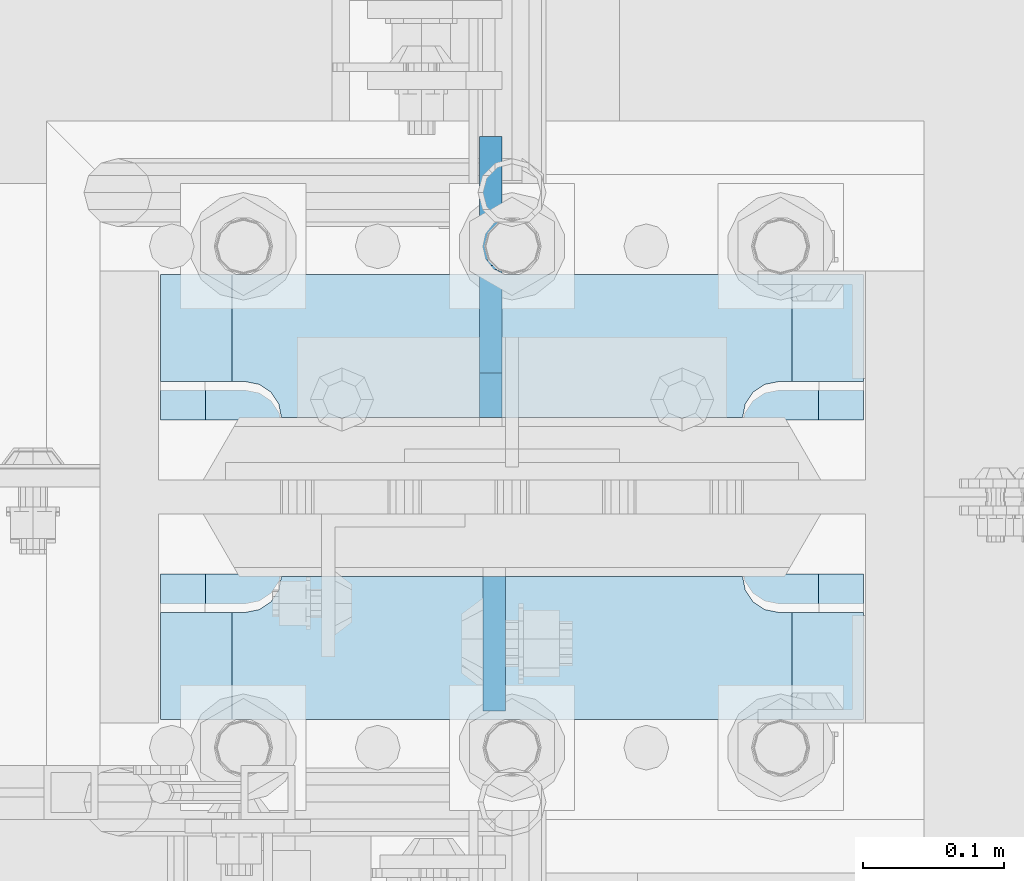
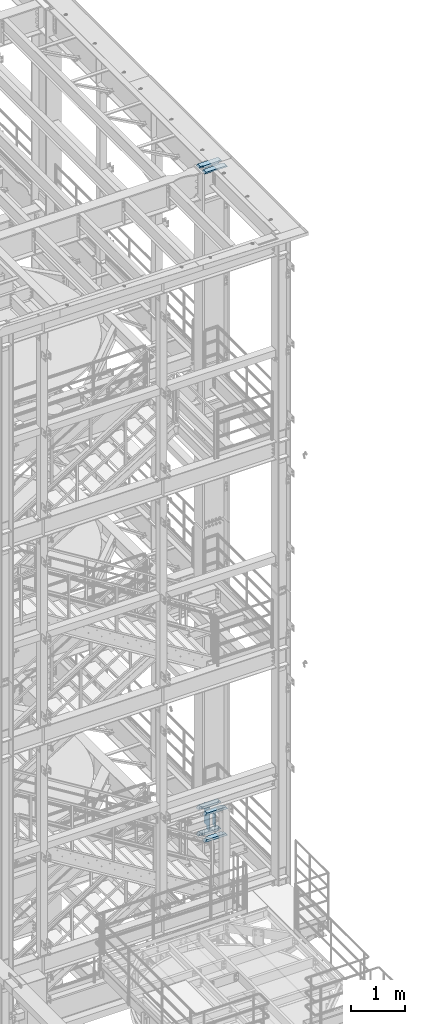
# One storey, part 1526 of 1876: 8 plates, 2 elements without a shape of their own.
"""IFC2X3 building model written with IfcOpenShell, lengths in millimetres."""

from ifc_helpers import new_model, si_unit, frame, origin_with_axes, place, context, subcontext, project, spatial, faceted_brep, material, type_object, element, aggregate, save


model = new_model("IFC2X3")

# Units and contexts
model_context = context("Model", 3, precision=1e-05, world=origin_with_axes())
body_context = subcontext(model_context, "Body", "Model", "MODEL_VIEW")
ifc_project = project(units=[si_unit("LENGTHUNIT", "METRE", prefix="MILLI"), si_unit("AREAUNIT", "SQUARE_METRE"), si_unit("VOLUMEUNIT", "CUBIC_METRE"), si_unit("MASSUNIT", "GRAM", prefix="KILO"), si_unit("TIMEUNIT", "SECOND"), si_unit("PLANEANGLEUNIT", "RADIAN"), si_unit("SOLIDANGLEUNIT", "STERADIAN"), si_unit("THERMODYNAMICTEMPERATUREUNIT", "DEGREE_CELSIUS"), si_unit("LUMINOUSINTENSITYUNIT", "LUMEN")], contexts=[model_context])

# Site, building, storey
site_placement = place(None, origin_with_axes())
site = spatial("IfcSite", under=ifc_project, at=site_placement, CompositionType="ELEMENT")
building_placement = place(site_placement, origin_with_axes())
building = spatial("IfcBuilding", under=site, at=building_placement, Name="Undefined", CompositionType="ELEMENT")
storey_placement = place(building_placement, origin_with_axes())
storey = spatial("IfcBuildingStorey", under=building, at=storey_placement, Name="Undefined", CompositionType="ELEMENT", Elevation=0.0)

# Assembly, plates
assembly_1_placement = place(storey_placement, origin_with_axes())
assembly_1 = element("IfcElementAssembly", 1, at=assembly_1_placement, inside=storey, Name="COLUMN", AssemblyPlace="NOTDEFINED", PredefinedType="RIGID_FRAME")
ifc_material_1 = material(Name="STEEL/A572-50")
plate_type_1 = type_object("IfcPlateType", PredefinedType="NOTDEFINED")
plate_1_placement = place(assembly_1_placement, frame((7869.2375, -4628.35625, 7531.10002441406), z_axis=(-1.0, 0.0, 0.0), x_axis=(0.0, -1.0, 0.0)))
plate_1 = element("IfcPlate", 2, at=plate_1_placement, type_object=plate_type_1, material=ifc_material_1, Name="PLATE", context=body_context, shape_type="Brep", body=[
    faceted_brep([(101.599998474121, -25.3999999999996, 498.475006103516), (101.599998474121, 25.3999999999996, 447.975004579813), (25.3999996185303, 25.3999999999996, 447.975004579813), (25.3999996185303, -25.3999999999996, 498.475006103516), (23.4665397733534, -25.3999999999996, 428.429848211837), (25.3999996185303, -25.3999999999996, 438.150007247925), (25.3999996185303, 25.3999999999996, 438.150007247925), (23.4665397733534, 25.3999999999996, 428.429848211837), (17.9605119723965, -25.3999999999996, 420.189495275529), (17.9605119723965, 25.3999999999996, 420.189495275529), (9.72015903608917, -25.3999999999996, 414.683467474573), (9.72015903608917, 25.3999999999996, 414.683467474573), (0.0, -25.3999999999996, 412.750007629395), (0.0, 25.3999999999996, 412.750007629395), (0.0, -25.3999999999996, 85.7249984741211), (0.0, 25.3999999999996, 85.7249984741211), (9.72015903609099, -25.3999999999996, 83.7915386289451), (9.72015903609099, 25.3999999999996, 83.7915386289451), (17.9605119723983, -25.3999999999996, 78.2855108279891), (17.9605119723983, 25.3999999999996, 78.2855108279891), (23.4665397733552, -25.3999999999996, 70.0451578916818), (23.4665397733552, 25.3999999999996, 70.0451578916818), (25.3999996185303, -25.3999999999996, 60.3249988555908), (25.3999996185303, 25.3999999999996, 60.3249988555908), (25.3999996185303, 25.3999999999996, 50.5000015237028), (25.3999996185303, -25.3999999999996, 0.0), (101.599998474121, 25.3999999999996, 50.5000015237028), (101.599998474121, -25.3999999999996, 0.0)], [[[0, 1, 2, 3]], [[4, 5, 6, 7]], [[8, 4, 7, 9]], [[10, 8, 9, 11]], [[12, 10, 11, 13]], [[14, 12, 13, 15]], [[16, 14, 15, 17]], [[18, 16, 17, 19]], [[20, 18, 19, 21]], [[22, 20, 21, 23]], [[22, 23, 24, 25]], [[26, 27, 25, 24]], [[5, 4, 8, 10, 12, 14, 16, 18, 20, 22, 25, 27, 0, 3]], [[6, 5, 3, 2]], [[26, 24, 23, 21, 19, 17, 15, 13, 11, 9, 7, 6, 2, 1]], [[27, 26, 1, 0]]]),
])
plate_2_placement = place(assembly_1_placement, frame((7869.2375, -4628.35625, 8128.0), z_axis=(-1.0, 0.0, 0.0), x_axis=(0.0, -1.0, 0.0)))
plate_2 = element("IfcPlate", 3, at=plate_2_placement, type_object=plate_type_1, material=ifc_material_1, Name="PLATE", context=body_context, shape_type="Brep", body=[
    faceted_brep([(101.599998474121, -25.3999999999996, 498.475006103516), (101.599998474121, 25.3999999999996, 447.975004579813), (25.3999996185303, 25.3999999999996, 447.975004579813), (25.3999996185303, -25.3999999999996, 498.475006103516), (23.4665397733534, -25.3999999999996, 428.429848211837), (25.3999996185303, -25.3999999999996, 438.150007247925), (25.3999996185303, 25.3999999999996, 438.150007247925), (23.4665397733534, 25.3999999999996, 428.429848211837), (17.9605119723965, -25.3999999999996, 420.189495275529), (17.9605119723965, 25.3999999999996, 420.189495275529), (9.72015903608917, -25.3999999999996, 414.683467474573), (9.72015903608917, 25.3999999999996, 414.683467474573), (0.0, -25.3999999999996, 412.750007629395), (0.0, 25.3999999999996, 412.750007629395), (0.0, -25.3999999999996, 85.7249984741211), (0.0, 25.3999999999996, 85.7249984741211), (9.72015903609099, -25.3999999999996, 83.7915386289451), (9.72015903609099, 25.3999999999996, 83.7915386289451), (17.9605119723983, -25.3999999999996, 78.2855108279891), (17.9605119723983, 25.3999999999996, 78.2855108279891), (23.4665397733552, -25.3999999999996, 70.0451578916818), (23.4665397733552, 25.3999999999996, 70.0451578916818), (25.3999996185303, -25.3999999999996, 60.3249988555908), (25.3999996185303, 25.3999999999996, 60.3249988555908), (25.3999996185303, 25.3999999999996, 50.5000015237028), (25.3999996185303, -25.3999999999996, 0.0), (101.599998474121, 25.3999999999996, 50.5000015237028), (101.599998474121, -25.3999999999996, 0.0)], [[[0, 1, 2, 3]], [[4, 5, 6, 7]], [[8, 4, 7, 9]], [[10, 8, 9, 11]], [[12, 10, 11, 13]], [[14, 12, 13, 15]], [[16, 14, 15, 17]], [[18, 16, 17, 19]], [[20, 18, 19, 21]], [[22, 20, 21, 23]], [[22, 23, 24, 25]], [[26, 27, 25, 24]], [[5, 4, 8, 10, 12, 14, 16, 18, 20, 22, 25, 27, 0, 3]], [[6, 5, 3, 2]], [[26, 24, 23, 21, 19, 17, 15, 13, 11, 9, 7, 6, 2, 1]], [[27, 26, 1, 0]]]),
])
plate_3_placement = place(assembly_1_placement, frame((7869.2375, -4414.04375, 7531.10002441406), z_axis=(-1.0, 0.0, 0.0), x_axis=(0.0, -1.0, 0.0)))
plate_3 = element("IfcPlate", 4, at=plate_3_placement, type_object=plate_type_1, material=ifc_material_1, Name="PLATE", context=body_context, shape_type="Brep", body=[
    faceted_brep([(76.1999988555908, -25.3999999999996, 498.475006103516), (76.1999988555908, 25.3999999999996, 447.975004579812), (0.0, 25.3999999999996, 447.975004579812), (0.0, -25.3999999999996, 498.475006103516), (76.1999988555908, 25.3999999999996, 50.5000015237032), (76.1999988555908, -25.3999999999996, 0.0), (0.0, -25.3999996185375, 0.0), (0.0, 25.3999999999996, 50.5000015237032), (76.1999988555908, 25.3999999999996, 60.3249988555908), (76.1999988555908, -25.3999999999996, 60.3249988555908), (78.1334587007668, -25.3999999999996, 70.045157891682), (78.1334587007668, 25.3999999999996, 70.045157891682), (83.6394865017228, -25.3999999999996, 78.2855108279893), (83.6394865017228, 25.3999999999996, 78.2855108279893), (91.8798394380301, -25.3999999999996, 83.7915386289454), (91.8798394380301, 25.3999999999996, 83.7915386289454), (101.599998474121, -25.3999999999996, 85.7249984741211), (101.599998474121, 25.3999999999996, 85.7249984741211), (101.599998474121, -25.3999999999996, 412.750007629395), (101.599998474121, 25.3999999999996, 412.750007629395), (91.8798394380301, -25.3999999999996, 414.68346747457), (91.8798394380301, 25.3999999999996, 414.68346747457), (83.6394865017219, -25.3999999999996, 420.189495275526), (83.6394865017219, 25.3999999999996, 420.189495275526), (78.1334587007659, -25.3999999999996, 428.429848211834), (78.1334587007659, 25.3999999999996, 428.429848211834), (76.1999988555908, -25.3999999999996, 438.150007247925), (76.1999988555908, 25.3999999999996, 438.150007247925)], [[[0, 1, 2, 3]], [[4, 5, 6, 7]], [[8, 9, 5, 4]], [[10, 9, 8, 11]], [[12, 10, 11, 13]], [[14, 12, 13, 15]], [[16, 14, 15, 17]], [[18, 16, 17, 19]], [[20, 18, 19, 21]], [[22, 20, 21, 23]], [[24, 22, 23, 25]], [[26, 24, 25, 27]], [[6, 5, 9, 10, 12, 14, 16, 18, 20, 22, 24, 26, 0, 3]], [[7, 6, 3, 2]], [[27, 25, 23, 21, 19, 17, 15, 13, 11, 8, 4, 7, 2, 1]], [[26, 27, 1, 0]]]),
])
plate_4_placement = place(assembly_1_placement, frame((7869.2375, -4414.04375, 8128.0), z_axis=(-1.0, 0.0, 0.0), x_axis=(0.0, -1.0, 0.0)))
plate_4 = element("IfcPlate", 5, at=plate_4_placement, type_object=plate_type_1, material=ifc_material_1, Name="PLATE", context=body_context, shape_type="Brep", body=[
    faceted_brep([(76.1999988555908, -25.3999999999996, 498.475006103516), (76.1999988555908, 25.3999999999996, 447.975004579812), (0.0, 25.3999999999996, 447.975004579812), (0.0, -25.3999999999996, 498.475006103516), (76.1999988555908, 25.3999999999996, 50.5000015237032), (76.1999988555908, -25.3999999999996, 0.0), (0.0, -25.3999996185375, 0.0), (0.0, 25.3999999999996, 50.5000015237032), (76.1999988555908, 25.3999999999996, 60.3249988555908), (76.1999988555908, -25.3999999999996, 60.3249988555908), (78.1334587007668, -25.3999999999996, 70.045157891682), (78.1334587007668, 25.3999999999996, 70.045157891682), (83.6394865017228, -25.3999999999996, 78.2855108279893), (83.6394865017228, 25.3999999999996, 78.2855108279893), (91.8798394380301, -25.3999999999996, 83.7915386289454), (91.8798394380301, 25.3999999999996, 83.7915386289454), (101.599998474121, -25.3999999999996, 85.7249984741211), (101.599998474121, 25.3999999999996, 85.7249984741211), (101.599998474121, -25.3999999999996, 412.750007629395), (101.599998474121, 25.3999999999996, 412.750007629395), (91.8798394380301, -25.3999999999996, 414.68346747457), (91.8798394380301, 25.3999999999996, 414.68346747457), (83.6394865017219, -25.3999999999996, 420.189495275526), (83.6394865017219, 25.3999999999996, 420.189495275526), (78.1334587007659, -25.3999999999996, 428.429848211834), (78.1334587007659, 25.3999999999996, 428.429848211834), (76.1999988555908, -25.3999999999996, 438.150007247925), (76.1999988555908, 25.3999999999996, 438.150007247925)], [[[0, 1, 2, 3]], [[4, 5, 6, 7]], [[8, 9, 5, 4]], [[10, 9, 8, 11]], [[12, 10, 11, 13]], [[14, 12, 13, 15]], [[16, 14, 15, 17]], [[18, 16, 17, 19]], [[20, 18, 19, 21]], [[22, 20, 21, 23]], [[24, 22, 23, 25]], [[26, 24, 25, 27]], [[6, 5, 9, 10, 12, 14, 16, 18, 20, 22, 24, 26, 0, 3]], [[7, 6, 3, 2]], [[27, 25, 23, 21, 19, 17, 15, 13, 11, 8, 4, 7, 2, 1]], [[26, 27, 1, 0]]]),
])
ifc_material_2 = material(Name="STEEL/A36")
plate_type_2 = type_object("IfcPlateType", PredefinedType="NOTDEFINED")
plate_5_placement = place(assembly_1_placement, frame((7607.30049991608, -4628.35625, 8089.9), z_axis=(0.0, -1.0, 0.0), x_axis=(0.0, 0.0, -1.0)))
plate_5 = element("IfcPlate", 6, at=plate_5_placement, type_object=plate_type_2, material=ifc_material_2, Name="PLATE", context=body_context, shape_type="Brep", body=[
    faceted_brep([(0.0, -7.9375, 0.0), (0.0, -7.9375, 95.25), (0.0, 7.9375, 95.25), (0.0, 7.9375, 0.0), (304.799987792969, -7.9375, 95.25), (304.799987792969, 7.9375, 95.25), (304.799987792969, -7.9375, 0.0), (304.799987792969, 7.9375, 0.0)], [[[0, 1, 2, 3]], [[1, 4, 5, 2]], [[4, 6, 7, 5]], [[6, 0, 3, 7]], [[5, 7, 3, 2]], [[6, 4, 1, 0]]]),
])

assembly_2_placement = place(storey_placement, origin_with_axes())
assembly_2 = element("IfcElementAssembly", 7, at=assembly_2_placement, inside=storey, Name="COLUMN", AssemblyPlace="NOTDEFINED", PredefinedType="RIGID_FRAME")
plate_type_3 = type_object("IfcPlateType", PredefinedType="NOTDEFINED")
plate_6_placement = place(assembly_2_placement, frame((7370.76249389648, -4560.09375, 22539.325), z_axis=(1.0, 0.0, 0.0), x_axis=(0.0, 1.0, 0.0)))
plate_6 = element("IfcPlate", 8, at=plate_6_placement, type_object=plate_type_3, material=ifc_material_1, Name="PLATE", context=body_context, shape_type="Brep", body=[
    faceted_brep([(35.0225766570229, -15.875, 84.7582685515335), (35.0225766570229, 15.875, 84.7582685515335), (39.1427531251766, 15.875, 82.0052546510551), (39.1427531251766, -15.875, 82.0052546510551), (41.895767025655, 15.875, 77.8850781829015), (41.895767025655, -15.875, 77.8850781829015), (42.8624969482426, 15.875, 73.024998664856), (42.8624969482426, -15.875, 73.024998664856), (42.8624969482426, 15.875, 31.7500061035162), (42.8624969482426, -15.875, 0.0), (146.050003051758, 15.875, 31.7500061035162), (146.049995422363, -15.875, 0.0), (146.050003051758, 15.875, 466.725012207031), (146.050003051758, -15.875, 498.475012207031), (42.8624969482426, 15.875, 466.725012207031), (42.8624969482426, -15.875, 498.475), (42.8624969482426, 15.875, 425.450001335144), (42.8624969482426, -15.875, 425.450001335144), (41.895767025655, 15.875, 420.589921817099), (41.895767025655, -15.875, 420.589921817099), (39.1427531251766, 15.875, 416.469745348945), (39.1427531251766, -15.875, 416.469745348945), (35.0225766570229, 15.875, 413.716731448467), (35.0225766570229, -15.875, 413.716731448467), (30.1624971389774, -15.875, 412.750001525879), (31.7500000000036, 15.875, 413.065775478188), (30.1624971389774, 14.2874971389756, 412.750001525879), (0.0, -15.875, 412.750007629395), (30.1624971389774, -15.875, 85.7249984741211), (0.0, -15.875, 85.7249984741211), (30.1624971389774, 14.2874971389756, 85.7249984741211), (31.7500000000036, 15.875, 85.4092245218126)], [[[0, 1, 2, 3]], [[3, 2, 4, 5]], [[5, 4, 6, 7]], [[7, 6, 8, 9]], [[10, 11, 9, 8]], [[11, 10, 12, 13]], [[13, 12, 14, 15]], [[16, 17, 15, 14]], [[17, 16, 18, 19]], [[19, 18, 20, 21]], [[21, 20, 22, 23]], [[24, 23, 22, 25, 26]], [[24, 26, 27]], [[28, 0, 3, 5, 7, 9, 11, 13, 15, 17, 19, 21, 23, 24, 27, 29]], [[28, 29, 30]], [[1, 0, 28, 30, 31]], [[22, 20, 18, 16, 14, 12, 10, 8, 6, 4, 2, 1, 31, 25]], [[30, 29, 27, 26, 25, 31]]]),
])
plate_7_placement = place(assembly_2_placement, frame((7370.76248779297, -4729.95625, 22539.325), z_axis=(1.0, 0.0, 0.0), x_axis=(0.0, 1.0, 0.0)))
plate_7 = element("IfcPlate", 9, at=plate_7_placement, type_object=plate_type_3, material=ifc_material_1, Name="PLATE", context=body_context, shape_type="Brep", body=[
    faceted_brep([(106.907246874825, -15.875, 82.0052546510551), (106.907246874825, 15.875, 82.0052546510551), (111.027423342978, 15.875, 84.7582685515335), (111.027423342978, -15.875, 84.7582685515335), (104.154232974346, -15.875, 77.8850781829015), (104.154232974346, 15.875, 77.8850781829015), (103.187503051759, -15.875, 73.024998664856), (103.187503051759, 15.875, 73.024998664856), (103.187503051759, -15.875, 0.0), (103.187503051759, 15.875, 31.7500061035153), (0.0, -15.875, 0.0), (0.0, 15.875, 31.75), (0.0, -15.875, 498.475006103516), (0.0, 15.875, 466.725006103516), (103.187503051759, -15.875, 498.475012207031), (103.187503051759, 15.875, 466.725012207031), (103.187503051759, -15.875, 425.450001335144), (103.187503051759, 15.875, 425.450001335144), (104.154232974346, -15.875, 420.589921817099), (104.154232974346, 15.875, 420.589921817099), (106.907246874825, -15.875, 416.469745348945), (106.907246874825, 15.875, 416.469745348945), (111.027423342978, -15.875, 413.716731448467), (111.027423342978, 15.875, 413.716731448467), (115.887502861024, -15.875, 412.750001525879), (146.050002288819, -15.875, 412.750001525879), (115.887502861024, 14.2875000396052, 412.750001525879), (114.300003053293, 15.875, 413.06577487085), (114.300003053293, 15.875, 85.4092251291504), (115.887502861024, -15.875, 85.7249984741211), (115.887502861024, 14.2875000396052, 85.7249984741211), (146.050002288819, -15.875, 85.7249984741211)], [[[0, 1, 2, 3]], [[4, 5, 1, 0]], [[6, 7, 5, 4]], [[7, 6, 8, 9]], [[9, 8, 10, 11]], [[11, 10, 12, 13]], [[14, 15, 13, 12]], [[16, 17, 15, 14]], [[18, 19, 17, 16]], [[20, 21, 19, 18]], [[22, 23, 21, 20]], [[24, 25, 26]], [[23, 22, 24, 26, 27]], [[2, 1, 5, 7, 9, 11, 13, 15, 17, 19, 21, 23, 27, 28]], [[29, 3, 2, 28, 30]], [[29, 30, 31]], [[24, 22, 20, 18, 16, 14, 12, 10, 8, 6, 4, 0, 3, 29, 31, 25]], [[30, 28, 27, 26, 25, 31]]]),
])
aggregate(assembly_2, [plate_6, plate_7])

# Plate
plate_type_4 = type_object("IfcPlateType", PredefinedType="NOTDEFINED")
plate_8_placement = place(assembly_1_placement, frame((7604.91949987411, -4515.64375, 8102.6), z_axis=(0.0, 1.0, 0.0), x_axis=(0.0, 0.0, -1.0)))
plate_8 = element("IfcPlate", 10, at=plate_8_placement, type_object=plate_type_4, material=ifc_material_2, Name="PLATE", context=body_context, shape_type="Brep", body=[
    faceted_brep([(469.900012207031, -7.9375, 199.231247384208), (469.900012207031, -7.9375, 116.681246757507), (469.900012207031, 7.9375, 116.681246757507), (469.900012207031, 7.9375, 199.231246948242), (470.866742129619, -7.9375, 111.821167239462), (470.866742129619, 7.9375, 111.821167239462), (473.619756030097, -7.9375, 107.700990771308), (473.619756030097, 7.9375, 107.700990771308), (477.739932498251, -7.9375, 104.94797687083), (477.739932498251, 7.9375, 104.94797687083), (482.600012016296, -7.9375, 103.981246948242), (482.600012016296, 7.9375, 103.981246948242), (546.099975585938, -7.9375, 103.981246948242), (546.099975585938, 7.9375, 103.981246948242), (12.6999996185305, -7.9375, 199.231249999999), (12.6999996185305, 7.9375, 199.231246948242), (12.6999996185305, 7.9375, 116.681249809264), (12.6999996185305, -7.9375, 116.681249809264), (11.7332696959429, 7.9375, 111.821170291219), (11.7332696959429, -7.9375, 111.821170291219), (8.98025579546447, 7.9375, 107.700993823065), (8.98025579546447, -7.9375, 107.700993823065), (4.86007932731081, 7.9375, 104.947979922586), (4.86007932731081, -7.9375, 104.947979922586), (0.0, 7.9375, 103.981249999999), (0.0, -7.9375, 103.981249999999), (0.0, 7.93749999999999, 31.75), (0.0, -7.93749999999998, 31.75), (31.75, -7.93749999999998, 0.0), (31.75, 7.93749999999999, 0.0), (514.349975585938, -7.9375, 0.0), (514.349975585938, 7.9375, 0.0), (546.099975585938, -7.9375, 31.75), (546.099975585938, 7.9375, 31.75)], [[[0, 1, 2, 3]], [[4, 5, 2, 1]], [[6, 7, 5, 4]], [[8, 9, 7, 6]], [[10, 11, 9, 8]], [[12, 13, 11, 10]], [[14, 15, 16, 17]], [[17, 16, 18, 19]], [[19, 18, 20, 21]], [[21, 20, 22, 23]], [[23, 22, 24, 25]], [[26, 27, 25, 24]], [[28, 27, 26, 29]], [[30, 28, 29, 31]], [[32, 30, 31, 33]], [[8, 6, 4, 1, 0, 14, 17, 19, 21, 23, 25, 27, 28, 30, 32, 12, 10]], [[15, 14, 0, 3]], [[33, 31, 29, 26, 24, 22, 20, 18, 16, 15, 3, 2, 5, 7, 9, 11, 13]], [[32, 33, 13, 12]]]),
])

aggregate(assembly_1, [plate_5, plate_1, plate_2, plate_3, plate_4, plate_8])

save(model, "model.ifc")
